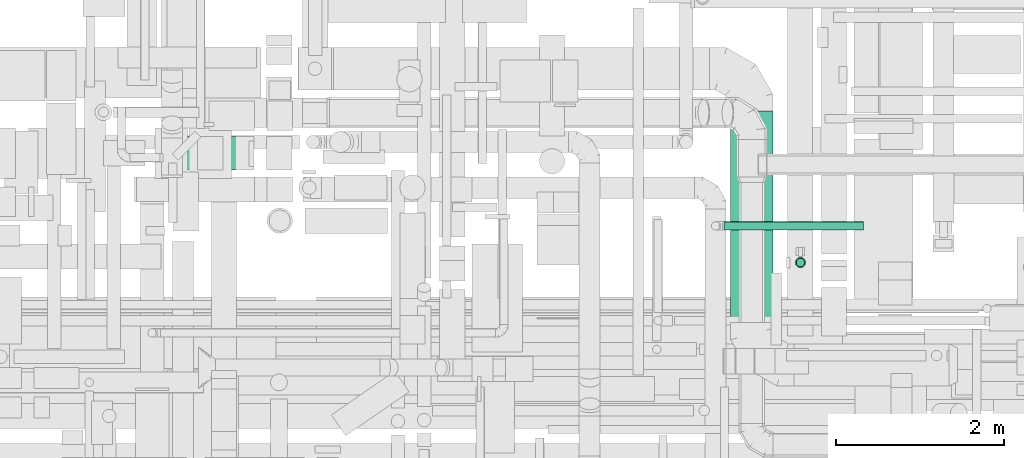
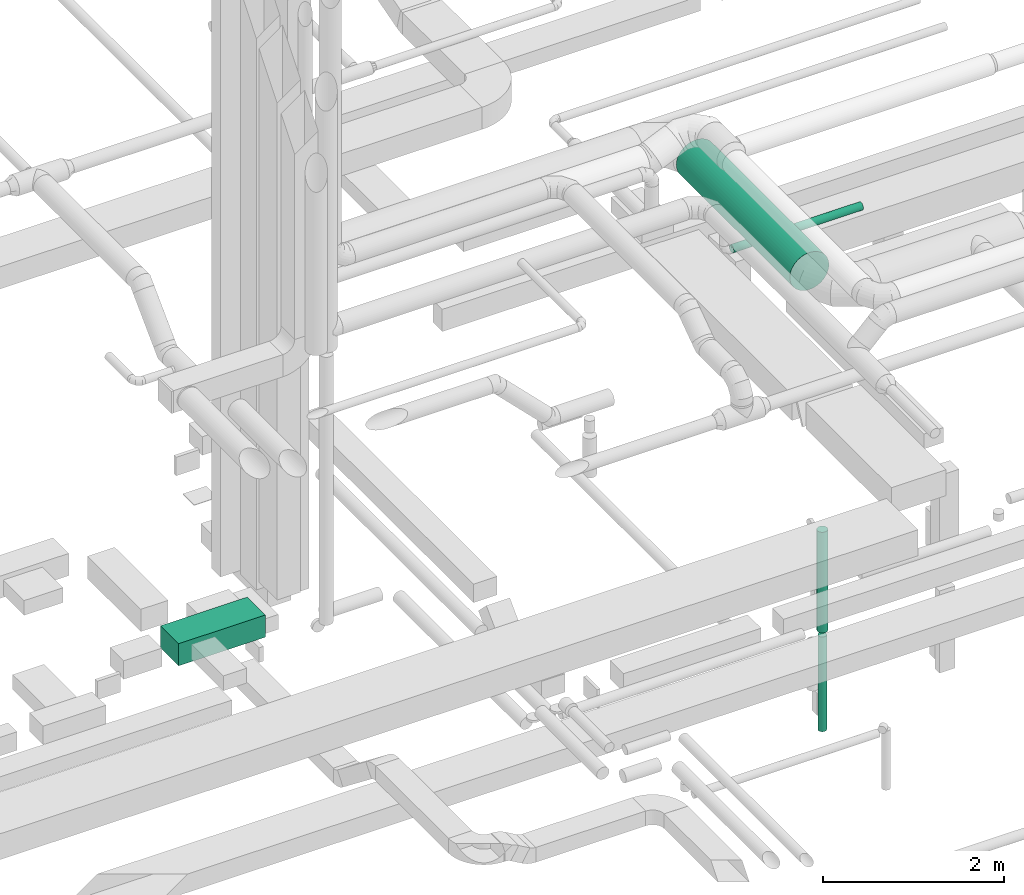
# One storey, part 34 of 337: 5 flow segments.
"""IFC2X3 building model written with IfcOpenShell, lengths in millimetres."""

from ifc_helpers import new_model, entity, si_unit, converted_unit, derived_unit, direction, frame, origin, origin_2d_with_axis, place, context, subcontext, project, spatial, rectangle, circle, extrude, type_object, element, save


model = new_model("IFC2X3")

# Units and contexts
model_context = context("Model", 3, precision=0.01, world=origin(), true_north=direction((6.12303176911189e-17, 1.0)))
body_context = subcontext(model_context, "Body", "Model", "MODEL_VIEW")
ifc_project = project(units=[si_unit("LENGTHUNIT", "METRE", prefix="MILLI"), si_unit("AREAUNIT", "SQUARE_METRE"), si_unit("VOLUMEUNIT", "CUBIC_METRE"), converted_unit("PLANEANGLEUNIT", "DEGREE", entity("IfcRatioMeasure", 0.0174532925199433), si_unit("PLANEANGLEUNIT", "RADIAN"), dimensions=[0, 0, 0, 0, 0, 0, 0]), si_unit("MASSUNIT", "GRAM", prefix="KILO"), derived_unit("MASSDENSITYUNIT", [(si_unit("MASSUNIT", "GRAM", prefix="KILO"), 1), (si_unit("LENGTHUNIT", "METRE"), -3)]), derived_unit("MOMENTOFINERTIAUNIT", [(si_unit("LENGTHUNIT", "METRE"), 4)]), si_unit("TIMEUNIT", "SECOND"), si_unit("FREQUENCYUNIT", "HERTZ"), si_unit("THERMODYNAMICTEMPERATUREUNIT", "DEGREE_CELSIUS"), derived_unit("THERMALTRANSMITTANCEUNIT", [(si_unit("MASSUNIT", "GRAM", prefix="KILO"), 1), (si_unit("THERMODYNAMICTEMPERATUREUNIT", "KELVIN"), -1), (si_unit("TIMEUNIT", "SECOND"), -3)]), derived_unit("VOLUMETRICFLOWRATEUNIT", [(si_unit("LENGTHUNIT", "METRE"), 3), (si_unit("TIMEUNIT", "SECOND"), -1)]), derived_unit("MASSFLOWRATEUNIT", [(si_unit("MASSUNIT", "GRAM", prefix="KILO"), 1), (si_unit("TIMEUNIT", "SECOND"), -1)]), derived_unit("ROTATIONALFREQUENCYUNIT", [(si_unit("TIMEUNIT", "SECOND"), -1)]), si_unit("ELECTRICCURRENTUNIT", "AMPERE"), si_unit("ELECTRICVOLTAGEUNIT", "VOLT"), si_unit("POWERUNIT", "WATT"), si_unit("FORCEUNIT", "NEWTON", prefix="KILO"), si_unit("ILLUMINANCEUNIT", "LUX"), si_unit("LUMINOUSFLUXUNIT", "LUMEN"), si_unit("LUMINOUSINTENSITYUNIT", "CANDELA"), derived_unit("USERDEFINED", [(si_unit("MASSUNIT", "GRAM", prefix="KILO"), -1), (si_unit("LENGTHUNIT", "METRE"), -2), (si_unit("TIMEUNIT", "SECOND"), 3), (si_unit("LUMINOUSFLUXUNIT", "LUMEN"), 1)]), derived_unit("LINEARVELOCITYUNIT", [(si_unit("LENGTHUNIT", "METRE"), 1), (si_unit("TIMEUNIT", "SECOND"), -1)]), si_unit("PRESSUREUNIT", "PASCAL"), derived_unit("USERDEFINED", [(si_unit("LENGTHUNIT", "METRE"), -2), (si_unit("MASSUNIT", "GRAM", prefix="KILO"), 1), (si_unit("TIMEUNIT", "SECOND"), -2)]), derived_unit("LINEARFORCEUNIT", [(si_unit("MASSUNIT", "GRAM", prefix="KILO"), 1), (si_unit("LENGTHUNIT", "METRE"), 1), (si_unit("TIMEUNIT", "SECOND"), -2), (si_unit("LENGTHUNIT", "METRE"), -1)]), derived_unit("PLANARFORCEUNIT", [(si_unit("MASSUNIT", "GRAM", prefix="KILO"), 1), (si_unit("LENGTHUNIT", "METRE"), 1), (si_unit("TIMEUNIT", "SECOND"), -2), (si_unit("LENGTHUNIT", "METRE"), -2)])], contexts=[model_context])

# Site, building, storey
site_placement = place(None, origin())
site = spatial("IfcSite", under=ifc_project, at=site_placement, CompositionType="ELEMENT")
building_placement = place(site_placement, origin())
building = spatial("IfcBuilding", under=site, at=building_placement, CompositionType="ELEMENT")
storey_placement = place(building_placement, origin())
storey = spatial("IfcBuildingStorey", under=building, at=storey_placement, CompositionType="ELEMENT", Elevation=0.0)

# Flow segments
duct_segment_type_1 = type_object("IfcDuctSegmentType", PredefinedType="NOTDEFINED")
flow_segment_1_placement = place(storey_placement, frame((29725.0, 11845.06, -900.0)))
element("IfcFlowSegment", 1, at=flow_segment_1_placement, inside=storey, type_object=duct_segment_type_1, context=body_context, shape_type="SweptSolid", body=[
    extrude(rectangle(XDim=1109.28505750001, YDim=400.0, at=origin_2d_with_axis()), frame((554.64, 200.0, 0.0)), (0.0, 0.0, 1.0), 300.0),
])
duct_segment_type_2 = type_object("IfcDuctSegmentType", PredefinedType="NOTDEFINED")
flow_segment_2_placement = place(storey_placement, frame((37271.43, 10695.87, -3750.0)))
element("IfcFlowSegment", 2, at=flow_segment_2_placement, inside=storey, type_object=duct_segment_type_2, context=body_context, shape_type="SweptSolid", body=[
    extrude(circle(Radius=50.0, at=origin_2d_with_axis()), frame((51.6, 51.6, 0.0), z_axis=(0.0, 0.0, 1.0), x_axis=(0.0, 1.0, 0.0)), (0.0, 0.0, 1.0), 1280.00007313086),
])
flow_segment_3_placement = place(storey_placement, frame((37258.93, 10683.37, -2406.0)))
element("IfcFlowSegment", 3, at=flow_segment_3_placement, inside=storey, type_object=duct_segment_type_2, context=body_context, shape_type="SweptSolid", body=[
    extrude(circle(Radius=62.5, at=origin_2d_with_axis()), frame((64.1, 64.1, 0.0), z_axis=(0.0, 0.0, 1.0), x_axis=(0.0, 1.0, 0.0)), (0.0, 0.0, 1.0), 1360.99992675),
])
flow_segment_4_placement = place(storey_placement, frame((36492.96, 10032.5, 2828.4)))
element("IfcFlowSegment", 4, at=flow_segment_4_placement, inside=storey, type_object=duct_segment_type_2, context=body_context, shape_type="SweptSolid", body=[
    extrude(circle(Radius=250.0, at=origin_2d_with_axis()), frame((251.6, 0.0, 251.6), z_axis=(0.0, 1.0, 0.0), x_axis=(1.0, 0.0, 0.0)), (0.0, 0.0, 1.0), 2516.06895364424),
])
flow_segment_5_placement = place(storey_placement, frame((36413.9, 11130.54, 2748.4)))
element("IfcFlowSegment", 5, at=flow_segment_5_placement, inside=storey, type_object=duct_segment_type_2, context=body_context, shape_type="SweptSolid", body=[
    extrude(circle(Radius=50.0, at=origin_2d_with_axis()), frame((0.0, 51.6, 51.6), z_axis=(1.0, 0.0, 0.0), x_axis=(0.0, -1.0, 0.0)), (0.0, 0.0, 1.0), 1656.85218484773),
])

save(model, "model.ifc")
